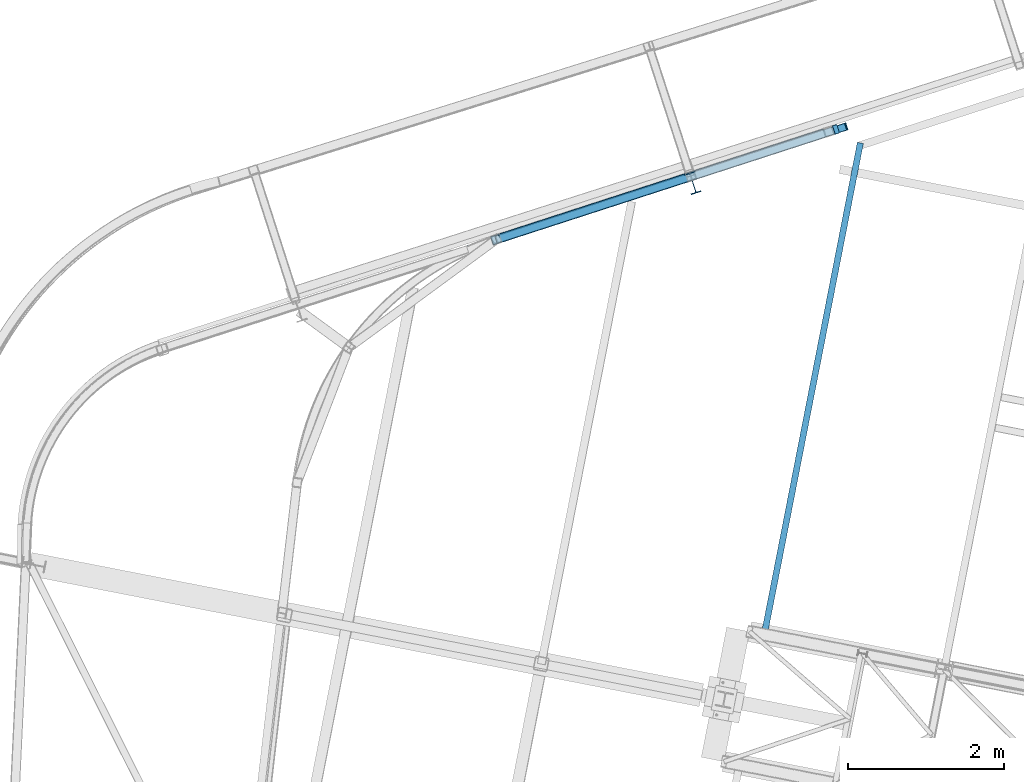
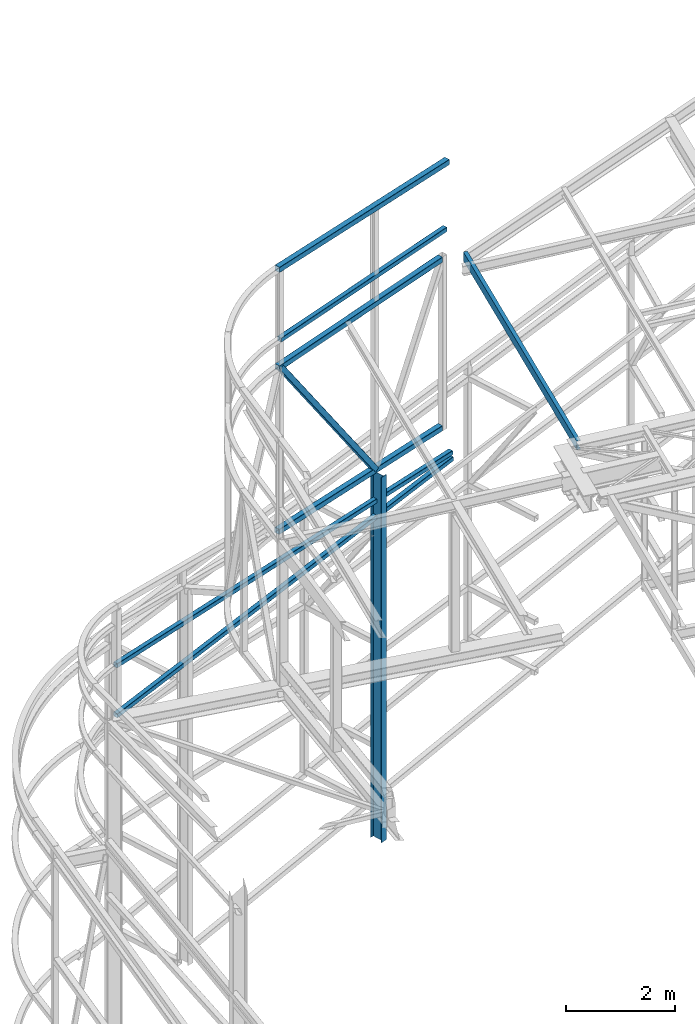
# One storey, part 81 of 215: 8 beams, 1 member, 9 elements without a shape of their own.
"""IFC2X3 building model written with IfcOpenShell, lengths in millimetres."""

from ifc_helpers import new_model, si_unit, frame, origin_with_axes, origin_2d_with_axis, place, context, subcontext, project, spatial, hollow_rectangle, i_section, u_section, extrude, material, type_object, element, aggregate, save


model = new_model("IFC2X3")

# Units and contexts
model_context = context("Model", 3, precision=1e-05, world=origin_with_axes())
body_context = subcontext(model_context, "Body", "Model", "MODEL_VIEW")
ifc_project = project(units=[si_unit("LENGTHUNIT", "METRE", prefix="MILLI"), si_unit("AREAUNIT", "SQUARE_METRE"), si_unit("VOLUMEUNIT", "CUBIC_METRE"), si_unit("MASSUNIT", "GRAM", prefix="KILO"), si_unit("TIMEUNIT", "SECOND"), si_unit("PLANEANGLEUNIT", "RADIAN"), si_unit("SOLIDANGLEUNIT", "STERADIAN"), si_unit("THERMODYNAMICTEMPERATUREUNIT", "DEGREE_CELSIUS"), si_unit("LUMINOUSINTENSITYUNIT", "LUMEN")], contexts=[model_context])

# Site, building, storey
site_placement = place(None, origin_with_axes())
site = spatial("IfcSite", under=ifc_project, at=site_placement, CompositionType="ELEMENT")
building_placement = place(site_placement, origin_with_axes())
building = spatial("IfcBuilding", under=site, at=building_placement, Name="Undefined", CompositionType="ELEMENT")
storey_placement = place(building_placement, origin_with_axes())
storey = spatial("IfcBuildingStorey", under=building, at=storey_placement, Name="Undefined", CompositionType="ELEMENT", Elevation=0.0)

# Assembly, beam
assembly_1_placement = place(storey_placement, origin_with_axes())
assembly_1 = element("IfcElementAssembly", 1, at=assembly_1_placement, inside=storey, Name="Steel Assembly", AssemblyPlace="NOTDEFINED", PredefinedType="RIGID_FRAME")
ifc_material = material(Name="STEEL/S275JR")
beam_type_1 = type_object("IfcBeamType", PredefinedType="NOTDEFINED")
beam_1_placement = place(assembly_1_placement, frame((45077.3713868133, 58519.7414048516, 12551.9665867203), z_axis=(-0.0257793249932949, -0.00835404399782583, 0.999632750739877), x_axis=(0.950947714759727, 0.308162424922138, 0.0270991449931531)))
beam_1 = element("IfcBeam", 2, at=beam_1_placement, type_object=beam_type_1, material=ifc_material, Name="LISSE", context=body_context, shape_type="SweptSolid", body=[
    extrude(hollow_rectangle(XDim=100.0, YDim=100.0, WallThickness=4.0, InnerFilletRadius=4.0, OuterFilletRadius=8.0, at=origin_2d_with_axis()), frame((4558.89803582273, -1.43848294245309e-11, 0.0), z_axis=(-1.0, 0.0, 0.0), x_axis=(-6.93889390390723e-18, -1.0, -3.46944695195361e-18)), (0.0, 0.0, 1.0), 4558.9),
])
aggregate(assembly_1, [beam_1])

assembly_2_placement = place(storey_placement, origin_with_axes())
assembly_2 = element("IfcElementAssembly", 3, at=assembly_2_placement, inside=storey, Name="Steel Assembly", AssemblyPlace="NOTDEFINED", PredefinedType="RIGID_FRAME")
beam_type_2 = type_object("IfcBeamType", Name="IPE270", PredefinedType="NOTDEFINED")
beam_2_placement = place(assembly_2_placement, frame((47604.414291094, 59248.2486089639, 8211.12763047336), z_axis=(0.308275434998926, -0.951297143996671, -1.00000033853226e-09), x_axis=(0.0, 0.0, -1.0)))
beam_2 = element("IfcBeam", 4, at=beam_2_placement, type_object=beam_type_2, material=ifc_material, Name="POTEAU", ObjectType="IPE270", context=body_context, shape_type="SweptSolid", body=[
    extrude(i_section(OverallWidth=135.0, OverallDepth=270.0, WebThickness=6.599999905, FlangeThickness=10.19999981, FilletRadius=15.0, at=origin_2d_with_axis()), frame((8211.12422736232, 7.27595761418343e-12, 0.0), z_axis=(-1.0, 0.0, 0.0), x_axis=(-6.93889390390723e-18, -1.0, -3.46944695195361e-18)), (0.0, 0.0, 1.0), 8211.1),
])
aggregate(assembly_2, [beam_2])

assembly_3_placement = place(storey_placement, origin_with_axes())
assembly_3 = element("IfcElementAssembly", 5, at=assembly_3_placement, inside=storey, Name="Steel Assembly", AssemblyPlace="NOTDEFINED", PredefinedType="RIGID_FRAME")
beam_type_3 = type_object("IfcBeamType", PredefinedType="NOTDEFINED")
beam_3_placement = place(assembly_3_placement, frame((45025.305676923, 58507.0739683088, 14159.9969824829), z_axis=(0.0, 0.0, 1.0), x_axis=(0.951297080141969, 0.308275632046006, 0.0)))
beam_3 = element("IfcBeam", 6, at=beam_3_placement, type_object=beam_type_3, material=ifc_material, Name="LISSE", context=body_context, shape_type="SweptSolid", body=[
    extrude(hollow_rectangle(XDim=120.0, YDim=120.0, WallThickness=4.0, InnerFilletRadius=4.0, OuterFilletRadius=8.0, at=origin_2d_with_axis()), frame((4668.89803636641, 0.0, 1.81898940354586e-12), z_axis=(-1.0, 0.0, 0.0), x_axis=(-6.93889390390723e-18, -1.0, -3.46944695195361e-18)), (0.0, 0.0, 1.0), 4668.9),
])
aggregate(assembly_3, [beam_3])

assembly_4_placement = place(storey_placement, origin_with_axes())
assembly_4 = element("IfcElementAssembly", 7, at=assembly_4_placement, inside=storey, Name="Steel Assembly", AssemblyPlace="NOTDEFINED", PredefinedType="RIGID_FRAME")
beam_type_4 = type_object("IfcBeamType", PredefinedType="NOTDEFINED")
beam_4_placement = place(assembly_4_placement, frame((49290.9157067348, 59889.3786880012, 12063.3539115877), z_axis=(0.308275434998926, -0.951297143996671, -1.00000033853226e-09), x_axis=(-0.950950059467171, -0.308162899827333, -0.0270113229848651)))
beam_4 = element("IfcBeam", 8, at=beam_4_placement, type_object=beam_type_4, material=ifc_material, Name="LISSE", context=body_context, shape_type="SweptSolid", body=[
    extrude(hollow_rectangle(XDim=120.0, YDim=120.0, WallThickness=5.0, InnerFilletRadius=5.0, OuterFilletRadius=10.0, at=origin_2d_with_axis()), frame((4484.00865728933, 1.80343237337729e-12, -7.44438102668142e-12), z_axis=(-1.0, 0.0, 0.0), x_axis=(-6.93889390390723e-18, -1.0, -3.46944695195361e-18)), (0.0, 0.0, 1.0), 4484.0),
])
aggregate(assembly_4, [beam_4])

assembly_5_placement = place(storey_placement, origin_with_axes())
assembly_5 = element("IfcElementAssembly", 9, at=assembly_5_placement, inside=storey, Name="Steel Assembly", AssemblyPlace="NOTDEFINED", PredefinedType="RIGID_FRAME")
beam_5_placement = place(assembly_5_placement, frame((49289.3739591442, 59888.8790726304, 8271.12763047336), z_axis=(0.308275434998926, -0.951297143996671, -1.00000033853226e-09), x_axis=(-0.951297161543401, -0.308275380852036, 0.0)))
beam_5 = element("IfcBeam", 10, at=beam_5_placement, type_object=beam_type_4, material=ifc_material, Name="LISSE", context=body_context, shape_type="SweptSolid", body=[
    extrude(hollow_rectangle(XDim=120.0, YDim=120.0, WallThickness=5.0, InnerFilletRadius=5.0, OuterFilletRadius=10.0, at=origin_2d_with_axis()), frame((4487.97205905666, 0.0, 0.0), z_axis=(-1.0, 0.0, 0.0), x_axis=(-6.93889390390723e-18, -1.0, -3.46944695195361e-18)), (0.0, 0.0, 1.0), 4488.0),
])
aggregate(assembly_5, [beam_5])

assembly_6_placement = place(storey_placement, origin_with_axes())
assembly_6 = element("IfcElementAssembly", 11, at=assembly_6_placement, inside=storey, Name="Steel Assembly", AssemblyPlace="NOTDEFINED", PredefinedType="RIGID_FRAME")
beam_type_5 = type_object("IfcBeamType", PredefinedType="NOTDEFINED")
beam_6_placement = place(assembly_6_placement, frame((40793.6034255014, 57130.6917211169, 6443.49278709594), z_axis=(-0.308132985984584, 0.951343293952411, 0.0), x_axis=(0.945976855838587, 0.306394836947719, 0.106065979981902)))
beam_6 = element("IfcBeam", 12, at=beam_6_placement, type_object=beam_type_5, material=ifc_material, Name="LISSE", context=body_context, shape_type="SweptSolid", body=[
    extrude(hollow_rectangle(XDim=100.0, YDim=100.0, WallThickness=5.0, InnerFilletRadius=5.0, OuterFilletRadius=10.0, at=origin_2d_with_axis()), frame((9286.0387535549, 1.03836437716991e-12, 9.55124005961263e-13), z_axis=(-1.0, 0.0, 0.0), x_axis=(-6.93889390390723e-18, -1.0, -3.46944695195361e-18)), (0.0, 0.0, 1.0), 9286.0),
])
aggregate(assembly_6, [beam_6])

assembly_7_placement = place(storey_placement, origin_with_axes())
assembly_7 = element("IfcElementAssembly", 13, at=assembly_7_placement, inside=storey, Name="Steel Assembly", AssemblyPlace="NOTDEFINED", PredefinedType="RIGID_FRAME")
beam_7_placement = place(assembly_7_placement, frame((40789.0161780722, 57129.2059463695, 7572.88876973563), z_axis=(-0.308132986072728, 0.95134329322455, 3.64770000082596e-05), x_axis=(0.951343293952411, 0.308132985984586, 0.0)))
beam_7 = element("IfcBeam", 14, at=beam_7_placement, type_object=beam_type_5, material=ifc_material, Name="LISSE", context=body_context, shape_type="SweptSolid", body=[
    extrude(hollow_rectangle(XDim=100.0, YDim=100.0, WallThickness=5.0, InnerFilletRadius=5.0, OuterFilletRadius=10.0, at=origin_2d_with_axis()), frame((9220.11910211988, -9.09479082283614e-13, 0.0), z_axis=(-1.0, 0.0, 0.0), x_axis=(-6.93889390390723e-18, -1.0, -3.46944695195361e-18)), (0.0, 0.0, 1.0), 9220.1),
])
aggregate(assembly_7, [beam_7])

# Assembly, member
assembly_8_placement = place(storey_placement, origin_with_axes())
assembly_8 = element("IfcElementAssembly", 15, at=assembly_8_placement, inside=storey, Name="Steel Assembly", AssemblyPlace="NOTDEFINED", PredefinedType="RIGID_FRAME")
member_type = type_object("IfcMemberType", PredefinedType="NOTDEFINED")
member_placement = place(assembly_8_placement, frame((45082.3834893184, 58525.5704850202, 11943.8123838444), z_axis=(-0.774238117979152, -0.250897994993243, -0.581038322984354), x_axis=(0.552740107132798, 0.179119810043033, -0.813876199195536)))
member = element("IfcMember", 16, at=member_placement, type_object=member_type, material=ifc_material, context=body_context, shape_type="SweptSolid", body=[
    extrude(hollow_rectangle(XDim=120.0, YDim=120.0, WallThickness=5.0, InnerFilletRadius=5.0, OuterFilletRadius=10.0, at=origin_2d_with_axis()), frame((4512.58404726879, -7.15610622096361e-12, -5.00997470983398e-13), z_axis=(-1.0, 0.0, 0.0), x_axis=(-6.93889390390723e-18, -1.0, -3.46944695195361e-18)), (0.0, 0.0, 1.0), 4512.6),
])
aggregate(assembly_8, [member])

# Assembly, beam
assembly_9_placement = place(storey_placement, origin_with_axes())
assembly_9 = element("IfcElementAssembly", 17, at=assembly_9_placement, inside=storey, Name="Steel Assembly", AssemblyPlace="NOTDEFINED", PredefinedType="RIGID_FRAME")
beam_type_6 = type_object("IfcBeamType", Name="UPE200", PredefinedType="NOTDEFINED")
beam_8_placement = place(assembly_9_placement, frame((48518.9241113197, 53455.811742043, 12036.1036244111), z_axis=(0.0, 0.0, 1.0), x_axis=(0.191834236022633, 0.981427341115792, 0.0)))
beam_8 = element("IfcBeam", 18, at=beam_8_placement, type_object=beam_type_6, material=ifc_material, ObjectType="UPE200", context=body_context, shape_type="SweptSolid", body=[
    extrude(u_section(Depth=200.0, FlangeWidth=80.0, WebThickness=6.0, FlangeThickness=11.0, FilletRadius=13.0, at=origin_2d_with_axis()), frame((6426.7476919451, -7.45433569570978e-12, 1.81898940354586e-12), z_axis=(-1.0, 0.0, 0.0), x_axis=(-6.93889390390723e-18, -1.0, -3.46944695195361e-18)), (0.0, 0.0, 1.0), 6426.7),
])
aggregate(assembly_9, [beam_8])

save(model, "model.ifc")
